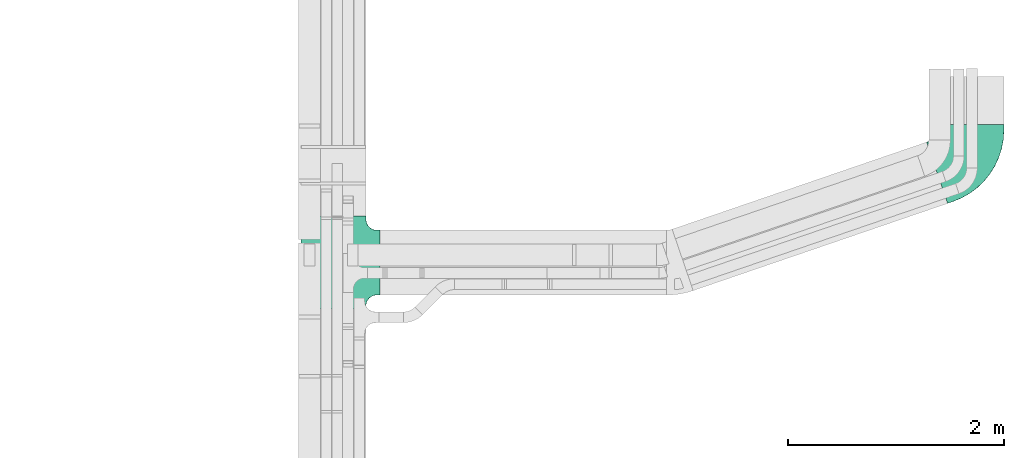
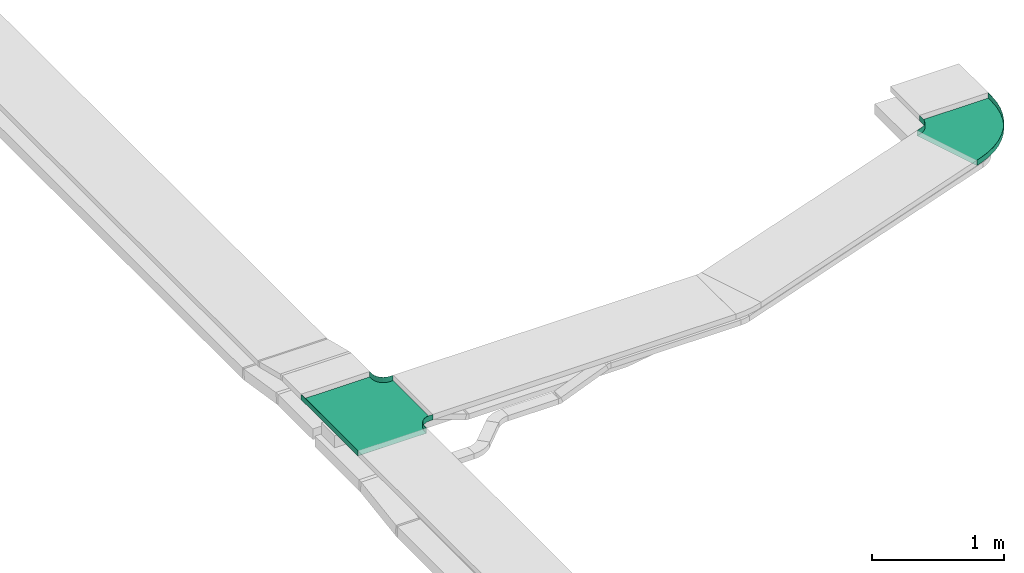
# One storey, part 34 of 38: 2 flow fittings.
"""IFC2X3 building model written with IfcOpenShell, lengths in millimetres."""

from ifc_helpers import new_model, entity, si_unit, converted_unit, derived_unit, direction, frame, origin, place, context, subcontext, project, spatial, faceted_brep, source, transform, mapped, material, type_object, type_shapes, element, save


model = new_model("IFC2X3")

# Units and contexts
model_context = context("Model", 3, precision=0.01, world=origin(), true_north=direction((6.12303176911189e-17, 1.0)))
body_context = subcontext(model_context, "Body", "Model", "MODEL_VIEW")
ifc_project = project(units=[si_unit("LENGTHUNIT", "METRE", prefix="MILLI"), si_unit("AREAUNIT", "SQUARE_METRE"), si_unit("VOLUMEUNIT", "CUBIC_METRE"), converted_unit("PLANEANGLEUNIT", "DEGREE", entity("IfcRatioMeasure", 0.0174532925199433), si_unit("PLANEANGLEUNIT", "RADIAN"), dimensions=[0, 0, 0, 0, 0, 0, 0]), si_unit("MASSUNIT", "GRAM", prefix="KILO"), derived_unit("MASSDENSITYUNIT", [(si_unit("MASSUNIT", "GRAM", prefix="KILO"), 1), (si_unit("LENGTHUNIT", "METRE"), -3)]), derived_unit("MOMENTOFINERTIAUNIT", [(si_unit("LENGTHUNIT", "METRE"), 4)]), si_unit("TIMEUNIT", "SECOND"), si_unit("FREQUENCYUNIT", "HERTZ"), si_unit("THERMODYNAMICTEMPERATUREUNIT", "DEGREE_CELSIUS"), derived_unit("THERMALTRANSMITTANCEUNIT", [(si_unit("MASSUNIT", "GRAM", prefix="KILO"), 1), (si_unit("THERMODYNAMICTEMPERATUREUNIT", "KELVIN"), -1), (si_unit("TIMEUNIT", "SECOND"), -3)]), derived_unit("VOLUMETRICFLOWRATEUNIT", [(si_unit("LENGTHUNIT", "METRE"), 3), (si_unit("TIMEUNIT", "SECOND"), -1)]), derived_unit("MASSFLOWRATEUNIT", [(si_unit("MASSUNIT", "GRAM", prefix="KILO"), 1), (si_unit("TIMEUNIT", "SECOND"), -1)]), derived_unit("ROTATIONALFREQUENCYUNIT", [(si_unit("TIMEUNIT", "SECOND"), -1)]), si_unit("ELECTRICCURRENTUNIT", "AMPERE"), si_unit("ELECTRICVOLTAGEUNIT", "VOLT"), si_unit("POWERUNIT", "WATT"), si_unit("FORCEUNIT", "NEWTON", prefix="KILO"), si_unit("ILLUMINANCEUNIT", "LUX"), si_unit("LUMINOUSFLUXUNIT", "LUMEN"), si_unit("LUMINOUSINTENSITYUNIT", "CANDELA"), derived_unit("USERDEFINED", [(si_unit("MASSUNIT", "GRAM", prefix="KILO"), -1), (si_unit("LENGTHUNIT", "METRE"), -2), (si_unit("TIMEUNIT", "SECOND"), 3), (si_unit("LUMINOUSFLUXUNIT", "LUMEN"), 1)]), derived_unit("LINEARVELOCITYUNIT", [(si_unit("LENGTHUNIT", "METRE"), 1), (si_unit("TIMEUNIT", "SECOND"), -1)]), si_unit("PRESSUREUNIT", "PASCAL"), derived_unit("USERDEFINED", [(si_unit("LENGTHUNIT", "METRE"), -2), (si_unit("MASSUNIT", "GRAM", prefix="KILO"), 1), (si_unit("TIMEUNIT", "SECOND"), -2)]), derived_unit("LINEARFORCEUNIT", [(si_unit("MASSUNIT", "GRAM", prefix="KILO"), 1), (si_unit("LENGTHUNIT", "METRE"), 1), (si_unit("TIMEUNIT", "SECOND"), -2), (si_unit("LENGTHUNIT", "METRE"), -1)]), derived_unit("PLANARFORCEUNIT", [(si_unit("MASSUNIT", "GRAM", prefix="KILO"), 1), (si_unit("LENGTHUNIT", "METRE"), 1), (si_unit("TIMEUNIT", "SECOND"), -2), (si_unit("LENGTHUNIT", "METRE"), -2)])], contexts=[model_context])

# Site, building, storey
site_placement = place(None, frame((0.0, -0.00077364408347762, 0.0)))
site = spatial("IfcSite", under=ifc_project, at=site_placement, CompositionType="ELEMENT")
building_placement = place(site_placement, origin())
building = spatial("IfcBuilding", under=site, at=building_placement, CompositionType="ELEMENT")
storey_placement = place(building_placement, frame((0.0, 0.0, 4200.0)))
storey = spatial("IfcBuildingStorey", under=building, at=storey_placement, CompositionType="ELEMENT", Elevation=4200.0)

# Flow fittings
ifc_material = material()
cable_carrier_fitting_type_1 = type_object("IfcCableCarrierFittingType", PredefinedType="NOTDEFINED", material=ifc_material)
shared_shape_1 = source(origin(), body_context, "Body", "Brep", [
    faceted_brep([(-303.407417371086, -374.118095489752, 25.0), (-300.0, -400.0, 25.0), (-300.0, -430.0, 25.0), (-299.199999999993, -430.0, 25.0), (-299.199999999993, -400.0, 25.0), (-302.634676710055, -373.911040253671, 25.0), (-312.704639298522, -349.600000000004, 25.0), (-328.72363645639, -328.723636456399, 25.0), (-349.599999999995, -312.704639298532, 25.0), (-373.911040253662, -302.634676710065, 25.0), (-400.0, -299.200000000004, 25.0), (-430.0, -299.200000000004, 25.0), (-430.0, -300.0, 25.0), (-400.0, -300.0, 25.0), (-374.118095489745, -303.407417371099, 25.0), (-350.0, -313.397459621561, 25.0), (-329.28932188134, -329.289321881349, 25.0), (-313.39745962155, -350.0, 25.0), (430.0, -300.0, 25.0), (430.0, -299.200000000004, 25.0), (400.0, -299.200000000004, 25.0), (373.911040253717, -302.634676710066, 25.0), (349.600000000045, -312.704639298531, 25.0), (328.723636456434, -328.723636456398, 25.0), (312.704639298558, -349.600000000001, 25.0), (302.634676710081, -373.911040253668, 25.0), (299.200000000007, -400.0, 25.0), (299.200000000007, -430.0, 25.0), (300.0, -430.0, 25.0), (300.0, -400.0, 25.0), (303.407417371113, -374.11809548975, 25.0), (313.397459621587, -350.0, 25.0), (329.289321881385, -329.289321881348, 25.0), (350.0, -313.397459621561, 25.0), (374.1180954898, -303.4074173711, 25.0), (400.0, -300.0, 25.0), (430.0, 299.199999999995, 25.0), (430.0, 300.0, 25.0), (-430.0, 300.0, 25.0), (-430.0, 299.199999999995, 25.0), (-430.0, -300.0, -25.0), (-430.0, 300.0, -25.0), (430.0, 300.0, -25.0), (430.0, -300.0, -25.0), (400.0, -300.0, -25.0), (374.1180954898, -303.4074173711, -25.0), (350.0, -313.397459621561, -25.0), (329.289321881385, -329.289321881348, -25.0), (313.397459621587, -350.0, -25.0), (303.407417371113, -374.11809548975, -25.0), (300.0, -400.0, -25.0), (300.0, -430.0, -25.0), (-300.0, -430.0, -25.0), (-300.0, -400.0, -25.0), (-303.407417371086, -374.118095489752, -25.0), (-313.39745962155, -350.0, -25.0), (-329.28932188134, -329.289321881349, -25.0), (-350.0, -313.397459621561, -25.0), (-374.118095489745, -303.407417371099, -25.0), (-400.0, -300.0, -25.0), (-300.0, -400.0, -24.199999999986), (299.200000000007, -430.0, -24.199999999986), (-299.199999999993, -430.0, -24.199999999986), (-299.199999999993, -400.0, -24.199999999986), (-400.0, -299.200000000004, -24.199999999986), (-430.0, -299.200000000004, -24.199999999986), (430.0, -299.200000000004, -24.199999999986), (400.0, -299.200000000004, -24.199999999986), (-430.0, 299.199999999995, -24.199999999986), (-400.0, -300.0, -24.199999999986), (400.0, -300.0, -24.199999999986), (430.0, 299.199999999995, -24.199999999986), (299.200000000007, -400.0, -24.199999999986), (300.0, -400.0, -24.199999999986), (-373.911040253662, -302.634676710065, -24.199999999986), (-349.599999999995, -312.704639298532, -24.199999999986), (-328.72363645639, -328.7236364564, -24.199999999986), (-312.704639298522, -349.600000000004, -24.199999999986), (-302.634676710055, -373.911040253671, -24.199999999986), (302.634676710081, -373.911040253668, -24.199999999986), (312.704639298557, -349.600000000001, -24.199999999986), (328.723636456434, -328.723636456398, -24.199999999986), (349.600000000044, -312.704639298532, -24.199999999986), (373.911040253716, -302.634676710066, -24.199999999986)], [[[0, 1, 2, 3, 4, 5, 6, 7, 8, 9, 10, 11, 12, 13, 14, 15, 16, 17]], [[18, 19, 20, 21, 22, 23, 24, 25, 26, 27, 28, 29, 30, 31, 32, 33, 34, 35]], [[36, 37, 38, 39]], [[40, 41, 42, 43, 44, 45, 46, 47, 48, 49, 50, 51, 52, 53, 54, 55, 56, 57, 58, 59]], [[2, 1, 60, 53, 52]], [[3, 2, 52, 51, 28, 27, 61, 62]], [[4, 3, 62, 63]], [[11, 10, 64, 65]], [[20, 19, 66, 67]], [[39, 38, 41, 40, 12, 11, 65, 68]], [[13, 12, 40, 59, 69]], [[18, 35, 70, 44, 43]], [[19, 18, 43, 42, 37, 36, 71, 66]], [[27, 26, 72, 61]], [[29, 28, 51, 50, 73]], [[38, 37, 42, 41]], [[36, 39, 68, 71]], [[68, 65, 64, 74, 75, 76, 77, 78, 63, 62, 61, 72, 79, 80, 81, 82, 83, 67, 66, 71]], [[14, 13, 69, 59, 58]], [[58, 57, 15, 14]], [[15, 57, 56, 16]], [[0, 17, 55, 54]], [[0, 54, 53, 60, 1]], [[55, 17, 16, 56]], [[5, 4, 63, 78]], [[6, 5, 78, 77]], [[7, 6, 77, 76]], [[8, 7, 76, 75]], [[9, 8, 75, 74]], [[10, 9, 74, 64]], [[21, 20, 67, 83]], [[22, 21, 83, 82]], [[23, 22, 82, 81]], [[81, 80, 24, 23]], [[24, 80, 79, 25]], [[79, 72, 26, 25]], [[30, 29, 73, 50, 49]], [[31, 30, 49, 48]], [[31, 48, 47, 32]], [[33, 32, 47, 46]], [[45, 34, 33, 46]], [[34, 45, 44, 70, 35]]]),
])
type_shapes(cable_carrier_fitting_type_1, [shared_shape_1])
flow_fitting_1_placement = place(storey_placement, frame((61794.0334115341, 8693.32381905951, 2884.5), z_axis=(0.0, 0.0, 1.0), x_axis=(0.0, 1.0, 0.0)))
element("IfcFlowFitting", 1, at=flow_fitting_1_placement, inside=storey, type_object=cable_carrier_fitting_type_1, material=ifc_material, Name="470_DKC_S5_T", context=body_context, shape_type="MappedRepresentation", body=[
    mapped(shared_shape_1, transform((0.0, 0.0, 0.0), scale=1.0)),
])
cable_carrier_fitting_type_2 = type_object("IfcCableCarrierFittingType", Name="470_DKC_S5_CPO 45 horizontal angle:-", PredefinedType="NOTDEFINED", material=ifc_material)
shared_shape_2 = source(origin(), body_context, "Body", "Brep", [
    faceted_brep([(-336.972819781566, -300.0, -25.0), (-336.972819781566, -300.0, 25.0), (-336.972819781566, -299.200000000008, 25.0), (-336.972819781566, -299.200000000008, -24.2000000000019), (-336.972819781566, 299.199999999992, -24.2000000000019), (-336.972819781566, 299.199999999992, 25.0), (-336.972819781566, 300.0, 25.0), (-336.972819781566, 300.0, -25.0), (-285.775769464909, -300.0, -25.0), (-285.775769464909, -300.0, 25.0), (-199.149239503088, -294.619208132618, 25.0), (-113.854479049607, -278.559555162219, 25.0), (-31.2027833998345, -252.067937231943, 25.0), (47.5351858125778, -215.551628291257, 25.0), (121.148935375078, -169.572018792091, 25.0), (188.506750244883, -114.835985045468, 25.0), (248.573092186403, -52.1850219234958, 25.0), (300.424519816145, 17.4176940228239, 25.0), (343.263885305242, 92.9021121423133, 25.0), (376.432589483902, 173.107758311738, 25.0), (393.027180218434, 221.540779273469, 25.0), (392.270370665349, 221.800084692542, 25.0), (375.675779930817, 173.36706373081, 25.0), (342.544982842648, 93.2530811570077, 25.0), (299.754576628395, 17.8549309439407, 25.0), (247.962407773088, -51.6682390412975, 25.0), (187.964713079501, -114.247601062559, 25.0), (120.683878569546, -168.921079342042, 25.0), (47.1542590065463, -214.848140716067, 25.0), (-31.4937239553374, -251.322716732249, 25.0), (-114.050960524368, -277.784058527748, 25.0), (-199.248241251616, -293.825357609038, 25.0), (-285.775769464909, -299.200000000008, 25.0), (-285.775769464909, 299.199999999992, 25.0), (-255.008999786983, 304.010178229215, 25.0), (-227.178611967952, 317.981629293932, 25.0), (-204.940739452219, 339.780917286558, 25.0), (-190.417765776281, 367.327517196883, 25.0), (-173.823175041749, 415.760538158616, 25.0), (-174.579984594833, 416.019843577688, 25.0), (-191.174575329365, 367.586822615955, 25.0), (-205.582287309462, 340.258846514443, 25.0), (-227.643668773483, 318.63256874398, 25.0), (-255.253180498713, 304.772002211523, 25.0), (-285.775769464909, 300.0, 25.0), (-285.775769464909, -299.200000000008, -24.2000000000019), (-199.248241251616, -293.825357609038, -24.2000000000019), (-114.050960524368, -277.784058527748, -24.2000000000018), (-31.4937239553374, -251.322716732249, -24.2000000000018), (47.1542590065463, -214.848140716067, -24.2000000000018), (120.683878569546, -168.921079342042, -24.2000000000018), (187.964713079501, -114.247601062559, -24.2000000000018), (247.962407773088, -51.6682390412975, -24.2000000000018), (299.754576628395, 17.8549309439407, -24.2000000000018), (342.544982842648, 93.2530811570078, -24.2000000000018), (375.675779930817, 173.36706373081, -24.2000000000018), (392.270370665349, 221.800084692542, -24.2000000000018), (-173.823175041749, 415.760538158616, -24.2000000000019), (-190.417765776281, 367.327517196883, -24.2000000000019), (-204.940739452219, 339.780917286558, -24.2000000000019), (-227.178611967952, 317.981629293932, -24.2000000000019), (-255.008999786983, 304.010178229215, -24.2000000000019), (-285.775769464909, 299.199999999992, -24.2000000000019), (-285.775769464909, 300.0, -25.0), (-199.149239503088, -294.619208132618, -25.0), (-255.253180498713, 304.772002211523, -25.0), (-227.643668773483, 318.63256874398, -25.0), (-205.582287309462, 340.258846514443, -25.0), (-191.174575329365, 367.586822615955, -25.0), (-174.579984594833, 416.019843577688, -25.0), (393.027180218434, 221.540779273469, -25.0), (376.432589483902, 173.107758311738, -25.0), (343.263885305242, 92.9021121423132, -25.0), (300.424519816145, 17.4176940228239, -25.0), (248.573092186403, -52.1850219234959, -25.0), (188.506750244883, -114.835985045468, -25.0), (121.148935375078, -169.572018792091, -25.0), (47.5351858125778, -215.551628291257, -25.0), (-31.2027833998345, -252.067937231943, -25.0), (-113.854479049607, -278.559555162219, -25.0)], [[[0, 1, 2, 3, 4, 5, 6, 7]], [[1, 0, 8, 9]], [[1, 9, 10, 11, 12, 13, 14, 15, 16, 17, 18, 19, 20, 21, 22, 23, 24, 25, 26, 27, 28, 29, 30, 31, 32, 2]], [[5, 33, 34, 35, 36, 37, 38, 39, 40, 41, 42, 43, 44, 6]], [[3, 2, 32, 45]], [[4, 3, 45, 46, 47, 48, 49, 50, 51, 52, 53, 54, 55, 56, 57, 58, 59, 60, 61, 62]], [[5, 4, 62, 33]], [[7, 6, 44, 63]], [[64, 8, 0, 7, 63, 65, 66, 67, 68, 69, 70, 71, 72, 73, 74, 75, 76, 77, 78, 79]], [[10, 9, 8, 64]], [[77, 76, 14, 13]], [[11, 10, 64, 79]], [[12, 78, 77, 13]], [[78, 12, 11, 79]], [[15, 75, 74, 16]], [[17, 73, 72, 18]], [[74, 73, 17, 16]], [[18, 72, 71, 19]], [[75, 15, 14, 76]], [[46, 45, 32, 31]], [[28, 27, 50, 49]], [[47, 46, 31, 30]], [[28, 49, 48, 29]], [[30, 29, 48, 47]], [[52, 51, 26, 25]], [[54, 53, 24, 23]], [[25, 24, 53, 52]], [[55, 54, 23, 22]], [[27, 26, 51, 50]], [[62, 61, 34, 33]], [[34, 61, 60, 35]], [[59, 58, 37, 36]], [[59, 36, 35, 60]], [[43, 65, 63, 44]], [[42, 66, 65, 43]], [[41, 40, 68, 67]], [[66, 42, 41, 67]], [[69, 39, 38, 57, 56, 21, 20, 70]], [[19, 71, 70, 20]], [[55, 22, 21, 56]], [[37, 58, 57, 38]], [[68, 40, 39, 69]]]),
])
type_shapes(cable_carrier_fitting_type_2, [shared_shape_2])
flow_fitting_2_placement = place(storey_placement, frame((67694.0334115348, 9633.32381905925, 2884.5), z_axis=(8.12959457272506e-06, 0.0, 1.0), x_axis=(0.946011941324184, 0.324131773840365, -7.69069354417633e-06)))
element("IfcFlowFitting", 2, at=flow_fitting_2_placement, inside=storey, type_object=cable_carrier_fitting_type_2, material=ifc_material, Name="470_DKC_S5_45 horizontal angle", ObjectType="470_DKC_S5_CPO 45 horizontal angle:-", context=body_context, shape_type="MappedRepresentation", body=[
    mapped(shared_shape_2, transform((0.0, 0.0, 0.0), scale=1.0)),
])

save(model, "model.ifc")
